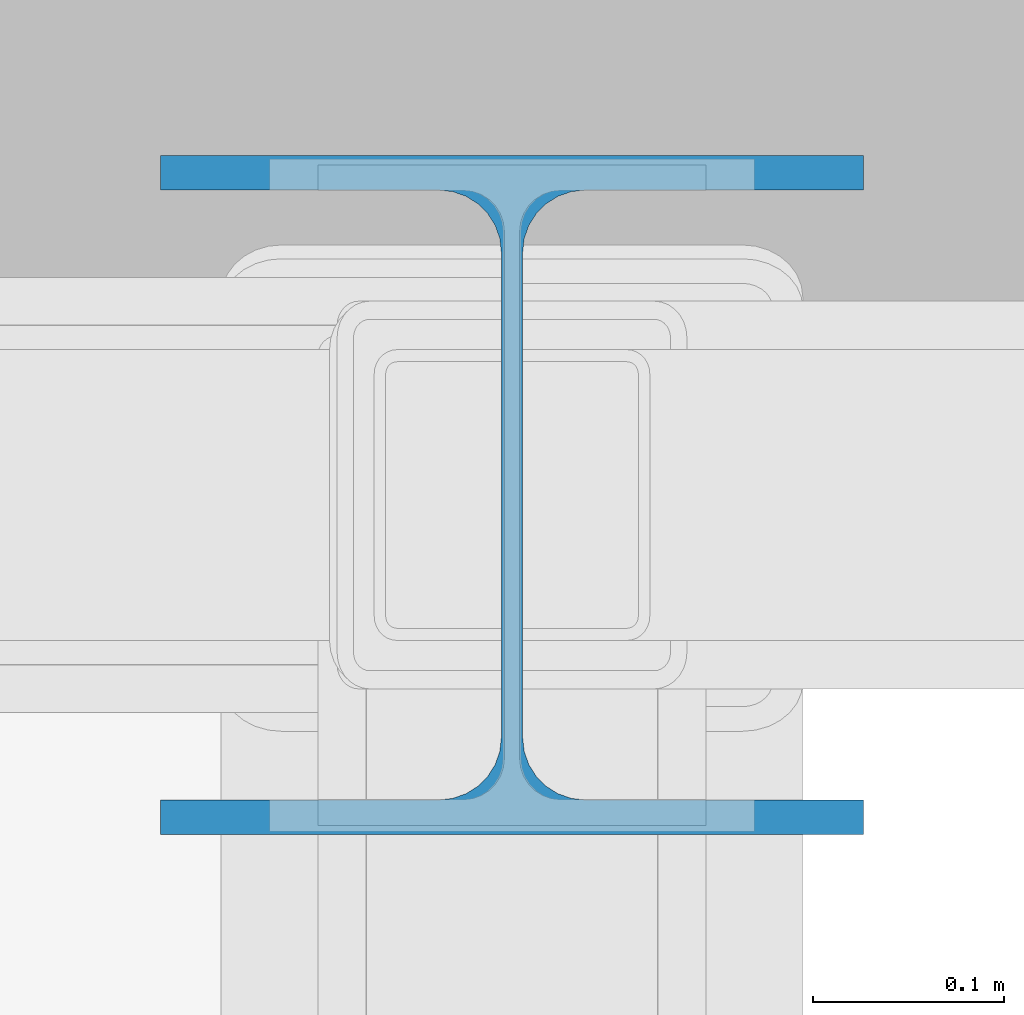
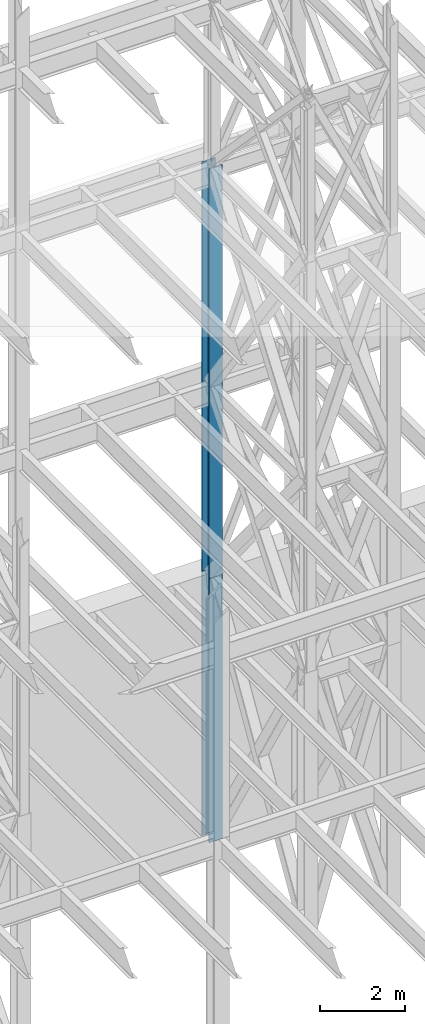
# One storey, part 107 of 150: 2 columns.
"""IFC2X3 building model written with IfcOpenShell, lengths in millimetres."""

from ifc_helpers import new_model, si_unit, frame, origin_with_axes, origin_2d_with_axis, place, context, subcontext, project, spatial, i_section, extrude, material, type_object, element, save


model = new_model("IFC2X3")

# Units and contexts
model_context = context("Model", 3, precision=1e-05, world=origin_with_axes())
body_context = subcontext(model_context, "Body", "Model", "MODEL_VIEW")
ifc_project = project(units=[si_unit("LENGTHUNIT", "METRE", prefix="MILLI"), si_unit("AREAUNIT", "SQUARE_METRE"), si_unit("VOLUMEUNIT", "CUBIC_METRE"), si_unit("MASSUNIT", "GRAM", prefix="KILO"), si_unit("TIMEUNIT", "SECOND"), si_unit("PLANEANGLEUNIT", "RADIAN"), si_unit("SOLIDANGLEUNIT", "STERADIAN"), si_unit("THERMODYNAMICTEMPERATUREUNIT", "DEGREE_CELSIUS"), si_unit("LUMINOUSINTENSITYUNIT", "LUMEN")], contexts=[model_context])

# Site, building, storey
site_placement = place(None, origin_with_axes())
site = spatial("IfcSite", under=ifc_project, at=site_placement, CompositionType="ELEMENT")
building_placement = place(site_placement, origin_with_axes())
building = spatial("IfcBuilding", under=site, at=building_placement, Name="Undefined", CompositionType="ELEMENT")
storey_placement = place(building_placement, origin_with_axes())
storey = spatial("IfcBuildingStorey", under=building, at=storey_placement, Name="Undefined", CompositionType="ELEMENT", Elevation=0.0)

# Columns
ifc_material = material(Name="STEEL/A992")
column_type = type_object("IfcColumnType", Name="W14X90", PredefinedType="NOTDEFINED")
column_1_placement = place(storey_placement, frame((74663.3, 31877.0, 23774.4), z_axis=(0.0, 0.0, 1.0), x_axis=(1.0, 0.0, 0.0)))
element("IfcColumn", 1, at=column_1_placement, inside=storey, type_object=column_type, material=ifc_material, Name="COLUMN", ObjectType="W14X90", context=body_context, shape_type="SweptSolid", body=[
    extrude(i_section(OverallWidth=368.3, OverallDepth=355.6, WebThickness=11.1125, FlangeThickness=18.034, FilletRadius=32.7659, at=origin_2d_with_axis()), frame((0.0, 0.0, 11811.0), z_axis=(0.0, 0.0, -1.0), x_axis=(-1.0, 0.0, 0.0)), (0.0, 0.0, 1.0), 11811.0),
])
column_2_placement = place(storey_placement, frame((74663.3, 31877.0, 16154.4), z_axis=(0.0, 0.0, 1.0), x_axis=(1.0, 0.0, 0.0)))
element("IfcColumn", 2, at=column_2_placement, inside=storey, type_object=column_type, material=ifc_material, Name="COLUMN", ObjectType="W14X90", context=body_context, shape_type="SweptSolid", body=[
    extrude(i_section(OverallWidth=368.3, OverallDepth=355.6, WebThickness=11.1125, FlangeThickness=18.034, FilletRadius=32.7659, at=origin_2d_with_axis()), frame((0.0, 0.0, 7620.0), z_axis=(0.0, 0.0, -1.0), x_axis=(-1.0, 0.0, 0.0)), (0.0, 0.0, 1.0), 7620.0),
])

save(model, "model.ifc")
